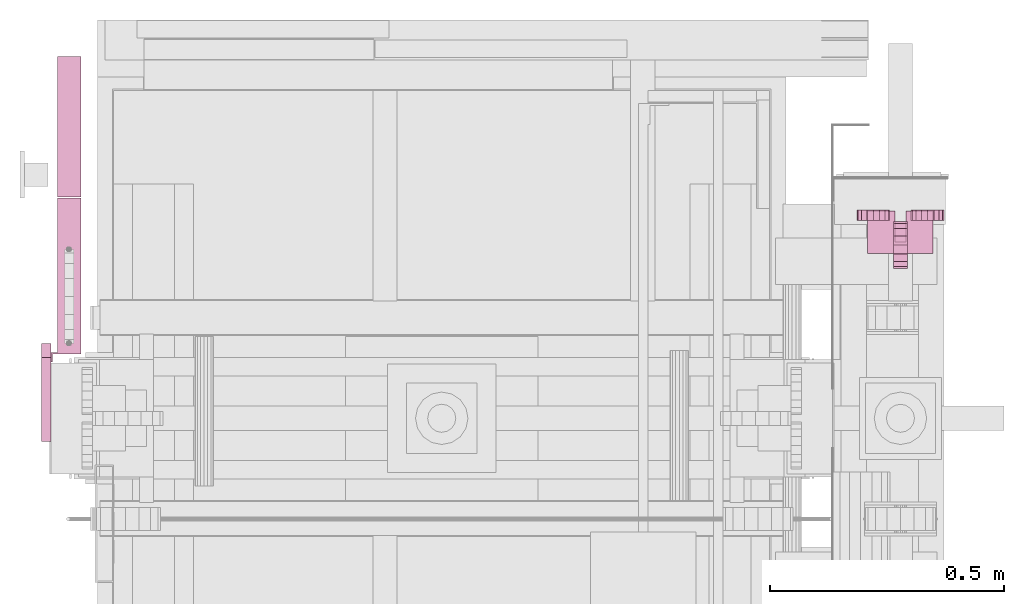
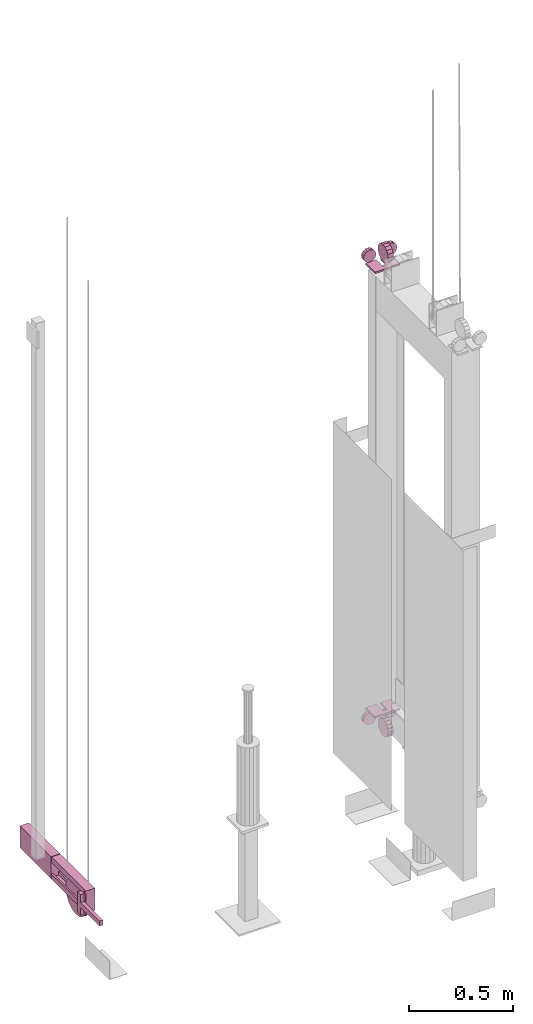
# One storey, part 13 of 13: 3 transport elements.
"""IFC4 building model written with IfcOpenShell, lengths in millimetres."""

from ifc_helpers import new_model, entity, si_unit, converted_unit, frame, origin_with_axes, place, context, subcontext, project, spatial, faceted_brep, element, save


model = new_model("IFC4")

# Units and contexts
context_of_model = context(None, 3, precision=0.01, world=origin_with_axes())
sub_context_1 = subcontext(context_of_model, None, None, "MODEL_VIEW")
sub_context_2 = subcontext(context_of_model, None, None, "MODEL_VIEW")
sub_context_3 = subcontext(context_of_model, None, None, "MODEL_VIEW")
ifc_project = project(units=[converted_unit("PLANEANGLEUNIT", "degree", entity("IfcPlaneAngleMeasure", 0.017453292519943), si_unit("PLANEANGLEUNIT", "RADIAN"), dimensions=[0, 0, 0, 0, 0, 0, 0]), si_unit("LENGTHUNIT", "METRE", prefix="MILLI"), si_unit("MASSUNIT", "GRAM", prefix="KILO"), converted_unit("TIMEUNIT", "year", entity("IfcTimeMeasure", 31557600.0), si_unit("TIMEUNIT", "SECOND"), dimensions=[0, 0, 1, 0, 0, 0, 0]), si_unit("THERMODYNAMICTEMPERATUREUNIT", "DEGREE_CELSIUS"), si_unit("AREAUNIT", "SQUARE_METRE"), si_unit("FORCEUNIT", "NEWTON"), si_unit("VOLUMEUNIT", "CUBIC_METRE"), si_unit("PRESSUREUNIT", "PASCAL"), si_unit("SOLIDANGLEUNIT", "STERADIAN")], contexts=[context_of_model])

# Site, building, storey
site = spatial("IfcSite", under=ifc_project)
building = spatial("IfcBuilding", under=site, Name="Document")
placement = place(None, origin_with_axes())
storey_placement = place(placement, frame((0.0, 0.0, -26400.0), z_axis=(0.0, 0.0, 1.0), x_axis=(1.0, 0.0, 0.0)))
storey = spatial("IfcBuildingStorey", under=building, at=storey_placement, Name="Z -26400", Elevation=-26400.0)

# Transport elements
transport_element_1_placement = place(storey_placement, frame((1879.0, 1447.0, 649.0), z_axis=(0.0, 0.0, -1.0), x_axis=(-1.0, 0.0, 0.0)))
element("IfcTransportElement", 1, at=transport_element_1_placement, inside=storey, ObjectType="R3", PredefinedType="ELEVATOR", context=sub_context_1, shape_type="Brep", body=[
    faceted_brep([(15.0, -52.0, 43.0), (15.0, -32.8658447265625, 46.8060302734375), (15.0, -16.6446533203125, 57.6446533203125), (15.0, -5.8060302734375, 73.8658447265625), (15.0, -2.0, 93.0), (15.0, -5.8060302734375, 112.1341552734375), (15.0, -16.6446533203125, 128.3553466796875), (15.0, -32.8658447265625, 139.1939697265625), (15.0, -52.0, 143.0), (15.0, -71.1341552734375, 139.1939697265625), (15.0, -87.3553466796875, 128.3553466796875), (15.0, -98.1939697265625, 112.1341552734375), (15.0, -102.0, 93.0), (15.0, -98.1939697265625, 73.8658447265625), (15.0, -87.3553466796875, 57.6446533203125), (15.0, -71.1341552734375, 46.8060302734375), (-15.0, -52.0, 43.0), (-15.0, -71.1341552734375, 46.8060302734375), (-15.0, -87.3553466796875, 57.6446533203125), (-15.0, -98.1939697265625, 73.8658447265625), (-15.0, -102.0, 93.0), (-15.0, -98.1939697265625, 112.1341552734375), (-15.0, -87.3553466796875, 128.3553466796875), (-15.0, -71.1341552734375, 139.1939697265625), (-15.0, -52.0, 143.0), (-15.0, -32.8658447265625, 139.1939697265625), (-15.0, -16.6446533203125, 128.3553466796875), (-15.0, -5.8060302734375, 112.1341552734375), (-15.0, -2.0, 93.0), (-15.0, -5.8060302734375, 73.8658447265625), (-15.0, -16.6446533203125, 57.6446533203125), (-15.0, -32.8658447265625, 46.8060302734375)], [[[0, 1, 2, 3, 4, 5, 6, 7, 8, 9, 10, 11, 12, 13, 14, 15]], [[16, 17, 18, 19, 20, 21, 22, 23, 24, 25, 26, 27, 28, 29, 30, 31]], [[0, 15, 17, 16]], [[15, 14, 18, 17]], [[14, 13, 19, 18]], [[13, 12, 20, 19]], [[12, 11, 21, 20]], [[11, 10, 22, 21]], [[10, 9, 23, 22]], [[9, 8, 24, 23]], [[8, 7, 25, 24]], [[7, 6, 26, 25]], [[6, 5, 27, 26]], [[5, 4, 28, 27]], [[4, 3, 29, 28]], [[3, 2, 30, 29]], [[2, 1, 31, 30]], [[1, 0, 16, 31]]]),
    faceted_brep([(70.0, -70.0, 0.0), (70.0, 20.0, 0.0), (70.0, 20.0, 10.0), (70.0, -70.0, 10.0), (12.0, 20.0, 10.0), (12.0, 20.0, 0.0), (12.0, -46.0, 0.0), (12.0, -46.0, 10.0), (-12.0, -46.0, 0.0), (-12.0, 20.0, 0.0), (-12.0, 20.0, 10.0), (-12.0, -46.0, 10.0), (-70.0, 20.0, 10.0), (-70.0, 20.0, 0.0), (-70.0, -70.0, 0.0), (-70.0, -70.0, 10.0)], [[[0, 1, 2, 3]], [[4, 5, 6, 7]], [[8, 9, 10, 11]], [[12, 13, 14, 15]], [[15, 14, 0, 3]], [[1, 5, 4, 2]], [[6, 8, 11, 7]], [[9, 13, 12, 10]], [[3, 2, 4, 7, 11, 10, 12, 15]], [[14, 13, 9, 8, 6, 5, 1, 0]]]),
    faceted_brep([(-92.93994140625, 0.0, 58.0), (-90.2757568359375, 0.0, 44.6060791015625), (-82.688720703125, 0.0, 33.25128173828125), (-71.3338623046875, 0.0, 25.66424560546875), (-57.93994140625, 0.0, 23.0), (-44.5460205078125, 0.0, 25.66424560546875), (-33.1912841796875, 0.0, 33.25128173828125), (-25.604248046875, 0.0, 44.6060791015625), (-22.93994140625, 0.0, 58.0), (-25.604248046875, 0.0, 71.3939208984375), (-33.1912841796875, 0.0, 82.74871826171875), (-44.5460205078125, 0.0, 90.33575439453125), (-57.93994140625, 0.0, 93.0), (-71.3338623046875, 0.0, 90.33575439453125), (-82.688720703125, 0.0, 82.74871826171875), (-90.2757568359375, 0.0, 71.3939208984375), (-92.93994140625, 23.0, 58.0), (-90.2757568359375, 23.0, 71.3939208984375), (-82.688720703125, 23.0, 82.74871826171875), (-71.3338623046875, 23.0, 90.33575439453125), (-57.93994140625, 23.0, 93.0), (-44.5460205078125, 23.0, 90.33575439453125), (-33.1912841796875, 23.0, 82.74871826171875), (-25.604248046875, 23.0, 71.3939208984375), (-22.93994140625, 23.0, 58.0), (-25.604248046875, 23.0, 44.6060791015625), (-33.1912841796875, 23.0, 33.25128173828125), (-44.5460205078125, 23.0, 25.66424560546875), (-57.93994140625, 23.0, 23.0), (-71.3338623046875, 23.0, 25.66424560546875), (-82.688720703125, 23.0, 33.25128173828125), (-90.2757568359375, 23.0, 44.6060791015625)], [[[0, 1, 2, 3, 4, 5, 6, 7, 8, 9, 10, 11, 12, 13, 14, 15]], [[16, 17, 18, 19, 20, 21, 22, 23, 24, 25, 26, 27, 28, 29, 30, 31]], [[0, 15, 17, 16]], [[15, 14, 18, 17]], [[14, 13, 19, 18]], [[13, 12, 20, 19]], [[12, 11, 21, 20]], [[11, 10, 22, 21]], [[10, 9, 23, 22]], [[9, 8, 24, 23]], [[8, 7, 25, 24]], [[7, 6, 26, 25]], [[6, 5, 27, 26]], [[5, 4, 28, 27]], [[4, 3, 29, 28]], [[3, 2, 30, 29]], [[2, 1, 31, 30]], [[1, 0, 16, 31]]]),
    faceted_brep([(22.93994140625, 23.0, 58.0), (25.604248046875, 23.0, 71.3939208984375), (33.1912841796875, 23.0, 82.74871826171875), (44.5460205078125, 23.0, 90.33575439453125), (57.93994140625, 23.0, 93.0), (71.3338623046875, 23.0, 90.33575439453125), (82.688720703125, 23.0, 82.74871826171875), (90.2757568359375, 23.0, 71.3939208984375), (92.93994140625, 23.0, 58.0), (90.2757568359375, 23.0, 44.6060791015625), (82.688720703125, 23.0, 33.25128173828125), (71.3338623046875, 23.0, 25.66424560546875), (57.93994140625, 23.0, 23.0), (44.5460205078125, 23.0, 25.66424560546875), (33.1912841796875, 23.0, 33.25128173828125), (25.604248046875, 23.0, 44.6060791015625), (22.93994140625, 0.0, 58.0), (25.604248046875, 0.0, 44.6060791015625), (33.1912841796875, 0.0, 33.25128173828125), (44.5460205078125, 0.0, 25.66424560546875), (57.93994140625, 0.0, 23.0), (71.3338623046875, 0.0, 25.66424560546875), (82.688720703125, 0.0, 33.25128173828125), (90.2757568359375, 0.0, 44.6060791015625), (92.93994140625, 0.0, 58.0), (90.2757568359375, 0.0, 71.3939208984375), (82.688720703125, 0.0, 82.74871826171875), (71.3338623046875, 0.0, 90.33575439453125), (57.93994140625, 0.0, 93.0), (44.5460205078125, 0.0, 90.33575439453125), (33.1912841796875, 0.0, 82.74871826171875), (25.604248046875, 0.0, 71.3939208984375)], [[[0, 1, 2, 3, 4, 5, 6, 7, 8, 9, 10, 11, 12, 13, 14, 15]], [[16, 17, 18, 19, 20, 21, 22, 23, 24, 25, 26, 27, 28, 29, 30, 31]], [[0, 15, 17, 16]], [[15, 14, 18, 17]], [[14, 13, 19, 18]], [[13, 12, 20, 19]], [[12, 11, 21, 20]], [[11, 10, 22, 21]], [[10, 9, 23, 22]], [[9, 8, 24, 23]], [[8, 7, 25, 24]], [[7, 6, 26, 25]], [[6, 5, 27, 26]], [[5, 4, 28, 27]], [[4, 3, 29, 28]], [[3, 2, 30, 29]], [[2, 1, 31, 30]], [[1, 0, 16, 31]]]),
])
transport_element_2_placement = place(storey_placement, frame((1879.0, 1447.0, 3249.0), z_axis=(0.0, 0.0, 1.0), x_axis=(1.0, 0.0, 0.0)))
element("IfcTransportElement", 2, at=transport_element_2_placement, inside=storey, ObjectType="R3", PredefinedType="ELEVATOR", context=sub_context_2, shape_type="Brep", body=[
    faceted_brep([(-92.93994140625, 0.0, 58.0), (-90.2757568359375, 0.0, 44.606201171875), (-82.688720703125, 0.0, 33.251220703125), (-71.3338623046875, 0.0, 25.664306640625), (-57.93994140625, 0.0, 23.0), (-44.5460205078125, 0.0, 25.664306640625), (-33.1912841796875, 0.0, 33.251220703125), (-25.604248046875, 0.0, 44.606201171875), (-22.93994140625, 0.0, 58.0), (-25.604248046875, 0.0, 71.393798828125), (-33.1912841796875, 0.0, 82.748779296875), (-44.5460205078125, 0.0, 90.335693359375), (-57.93994140625, 0.0, 93.0), (-71.3338623046875, 0.0, 90.335693359375), (-82.688720703125, 0.0, 82.748779296875), (-90.2757568359375, 0.0, 71.393798828125), (-92.93994140625, 23.0, 58.0), (-90.2757568359375, 23.0, 71.393798828125), (-82.688720703125, 23.0, 82.748779296875), (-71.3338623046875, 23.0, 90.335693359375), (-57.93994140625, 23.0, 93.0), (-44.5460205078125, 23.0, 90.335693359375), (-33.1912841796875, 23.0, 82.748779296875), (-25.604248046875, 23.0, 71.393798828125), (-22.93994140625, 23.0, 58.0), (-25.604248046875, 23.0, 44.606201171875), (-33.1912841796875, 23.0, 33.251220703125), (-44.5460205078125, 23.0, 25.664306640625), (-57.93994140625, 23.0, 23.0), (-71.3338623046875, 23.0, 25.664306640625), (-82.688720703125, 23.0, 33.251220703125), (-90.2757568359375, 23.0, 44.606201171875)], [[[0, 1, 2, 3, 4, 5, 6, 7, 8, 9, 10, 11, 12, 13, 14, 15]], [[16, 17, 18, 19, 20, 21, 22, 23, 24, 25, 26, 27, 28, 29, 30, 31]], [[0, 15, 17, 16]], [[15, 14, 18, 17]], [[14, 13, 19, 18]], [[13, 12, 20, 19]], [[12, 11, 21, 20]], [[11, 10, 22, 21]], [[10, 9, 23, 22]], [[9, 8, 24, 23]], [[8, 7, 25, 24]], [[7, 6, 26, 25]], [[6, 5, 27, 26]], [[5, 4, 28, 27]], [[4, 3, 29, 28]], [[3, 2, 30, 29]], [[2, 1, 31, 30]], [[1, 0, 16, 31]]]),
    faceted_brep([(15.0, -52.0, 43.0), (15.0, -32.8658447265625, 46.805908203125), (15.0, -16.6446533203125, 57.644775390625), (15.0, -5.8060302734375, 73.86572265625), (15.0, -2.0, 93.0), (15.0, -5.8060302734375, 112.13427734375), (15.0, -16.6446533203125, 128.355224609375), (15.0, -32.8658447265625, 139.194091796875), (15.0, -52.0, 143.0), (15.0, -71.1341552734375, 139.194091796875), (15.0, -87.3553466796875, 128.355224609375), (15.0, -98.1939697265625, 112.13427734375), (15.0, -102.0, 93.0), (15.0, -98.1939697265625, 73.86572265625), (15.0, -87.3553466796875, 57.644775390625), (15.0, -71.1341552734375, 46.805908203125), (-15.0, -52.0, 43.0), (-15.0, -71.1341552734375, 46.805908203125), (-15.0, -87.3553466796875, 57.644775390625), (-15.0, -98.1939697265625, 73.86572265625), (-15.0, -102.0, 93.0), (-15.0, -98.1939697265625, 112.13427734375), (-15.0, -87.3553466796875, 128.355224609375), (-15.0, -71.1341552734375, 139.194091796875), (-15.0, -52.0, 143.0), (-15.0, -32.8658447265625, 139.194091796875), (-15.0, -16.6446533203125, 128.355224609375), (-15.0, -5.8060302734375, 112.13427734375), (-15.0, -2.0, 93.0), (-15.0, -5.8060302734375, 73.86572265625), (-15.0, -16.6446533203125, 57.644775390625), (-15.0, -32.8658447265625, 46.805908203125)], [[[0, 1, 2, 3, 4, 5, 6, 7, 8, 9, 10, 11, 12, 13, 14, 15]], [[16, 17, 18, 19, 20, 21, 22, 23, 24, 25, 26, 27, 28, 29, 30, 31]], [[0, 15, 17, 16]], [[15, 14, 18, 17]], [[14, 13, 19, 18]], [[13, 12, 20, 19]], [[12, 11, 21, 20]], [[11, 10, 22, 21]], [[10, 9, 23, 22]], [[9, 8, 24, 23]], [[8, 7, 25, 24]], [[7, 6, 26, 25]], [[6, 5, 27, 26]], [[5, 4, 28, 27]], [[4, 3, 29, 28]], [[3, 2, 30, 29]], [[2, 1, 31, 30]], [[1, 0, 16, 31]]]),
    faceted_brep([(22.93994140625, 23.0, 58.0), (25.604248046875, 23.0, 71.393798828125), (33.1912841796875, 23.0, 82.748779296875), (44.5460205078125, 23.0, 90.335693359375), (57.93994140625, 23.0, 93.0), (71.3338623046875, 23.0, 90.335693359375), (82.688720703125, 23.0, 82.748779296875), (90.2757568359375, 23.0, 71.393798828125), (92.93994140625, 23.0, 58.0), (90.2757568359375, 23.0, 44.606201171875), (82.688720703125, 23.0, 33.251220703125), (71.3338623046875, 23.0, 25.664306640625), (57.93994140625, 23.0, 23.0), (44.5460205078125, 23.0, 25.664306640625), (33.1912841796875, 23.0, 33.251220703125), (25.604248046875, 23.0, 44.606201171875), (22.93994140625, 0.0, 58.0), (25.604248046875, 0.0, 44.606201171875), (33.1912841796875, 0.0, 33.251220703125), (44.5460205078125, 0.0, 25.664306640625), (57.93994140625, 0.0, 23.0), (71.3338623046875, 0.0, 25.664306640625), (82.688720703125, 0.0, 33.251220703125), (90.2757568359375, 0.0, 44.606201171875), (92.93994140625, 0.0, 58.0), (90.2757568359375, 0.0, 71.393798828125), (82.688720703125, 0.0, 82.748779296875), (71.3338623046875, 0.0, 90.335693359375), (57.93994140625, 0.0, 93.0), (44.5460205078125, 0.0, 90.335693359375), (33.1912841796875, 0.0, 82.748779296875), (25.604248046875, 0.0, 71.393798828125)], [[[0, 1, 2, 3, 4, 5, 6, 7, 8, 9, 10, 11, 12, 13, 14, 15]], [[16, 17, 18, 19, 20, 21, 22, 23, 24, 25, 26, 27, 28, 29, 30, 31]], [[0, 15, 17, 16]], [[15, 14, 18, 17]], [[14, 13, 19, 18]], [[13, 12, 20, 19]], [[12, 11, 21, 20]], [[11, 10, 22, 21]], [[10, 9, 23, 22]], [[9, 8, 24, 23]], [[8, 7, 25, 24]], [[7, 6, 26, 25]], [[6, 5, 27, 26]], [[5, 4, 28, 27]], [[4, 3, 29, 28]], [[3, 2, 30, 29]], [[2, 1, 31, 30]], [[1, 0, 16, 31]]]),
    faceted_brep([(-70.0, -70.0, 10.0), (-70.0, 20.0, 10.0), (-70.0, 20.0, 0.0), (-70.0, -70.0, 0.0), (-12.0, 20.0, 0.0), (-12.0, 20.0, 10.0), (-12.0, -46.0, 10.0), (-12.0, -46.0, 0.0), (12.0, -46.0, 10.0), (12.0, 20.0, 10.0), (12.0, 20.0, 0.0), (12.0, -46.0, 0.0), (70.0, 20.0, 0.0), (70.0, 20.0, 10.0), (70.0, -70.0, 10.0), (70.0, -70.0, 0.0)], [[[0, 1, 2, 3]], [[4, 5, 6, 7]], [[8, 9, 10, 11]], [[12, 13, 14, 15]], [[15, 14, 0, 3]], [[1, 5, 4, 2]], [[6, 8, 11, 7]], [[9, 13, 12, 10]], [[2, 4, 7, 11, 10, 12, 15, 3]], [[0, 14, 13, 9, 8, 6, 5, 1]]]),
])
transport_element_3_placement = place(storey_placement, frame((105.0, 1285.0, 245.0), z_axis=(0.0, 0.0, 1.0), x_axis=(0.0, 1.0, 0.0)))
element("IfcTransportElement", 3, at=transport_element_3_placement, inside=storey, Name="TW0", ObjectType="-GBP Tension Weight", PredefinedType="ELEVATOR", context=sub_context_3, shape_type="Brep", body=[
    faceted_brep([(0.0, -10.0, -100.0), (38.268310546875, -10.0, -92.38795471191406), (70.710693359375, -10.0, -70.71067810058594), (92.387939453125, -10.0, -38.268341064453125), (100.0, -10.0, 0.0), (92.387939453125, -10.0, 38.268341064453125), (70.710693359375, -10.0, 70.710693359375), (38.268310546875, -10.0, 92.387939453125), (0.0, -10.0, 100.0), (-38.268310546875, -10.000000000000014, 92.387939453125), (-70.710693359375, -10.000000000000014, 70.710693359375), (-92.387939453125, -10.000000000000014, 38.268341064453125), (-100.0, -10.000000000000014, 0.0), (-92.387939453125, -10.000000000000014, -38.268341064453125), (-70.710693359375, -10.000000000000014, -70.71067810058594), (-38.268310546875, -10.000000000000014, -92.38795471191406), (0.0, 10.0, -100.0), (-38.268310546875, 9.999999999999986, -92.38795471191406), (-70.710693359375, 9.999999999999986, -70.71067810058594), (-92.387939453125, 9.999999999999986, -38.268341064453125), (-100.0, 9.999999999999986, 0.0), (-92.387939453125, 9.999999999999986, 38.268341064453125), (-70.710693359375, 9.999999999999986, 70.710693359375), (-38.268310546875, 9.999999999999986, 92.387939453125), (0.0, 10.0, 100.0), (38.268310546875, 10.0, 92.387939453125), (70.710693359375, 10.0, 70.710693359375), (92.387939453125, 10.0, 38.268341064453125), (100.0, 10.0, 0.0), (92.387939453125, 10.0, -38.268341064453125), (70.710693359375, 10.0, -70.71067810058594), (38.268310546875, 10.0, -92.38795471191406)], [[[0, 1, 2, 3, 4, 5, 6, 7, 8, 9, 10, 11, 12, 13, 14, 15]], [[16, 17, 18, 19, 20, 21, 22, 23, 24, 25, 26, 27, 28, 29, 30, 31]], [[0, 15, 17, 16]], [[15, 14, 18, 17]], [[14, 13, 19, 18]], [[13, 12, 20, 19]], [[12, 11, 21, 20]], [[11, 10, 22, 21]], [[10, 9, 23, 22]], [[9, 8, 24, 23]], [[8, 7, 25, 24]], [[7, 6, 26, 25]], [[6, 5, 27, 26]], [[5, 4, 28, 27]], [[4, 3, 29, 28]], [[3, 2, 30, 29]], [[2, 1, 31, 30]], [[1, 0, 16, 31]]]),
    faceted_brep([(-120.0, 24.999999999999986, 115.0), (210.0, 25.0, 115.0), (210.0, 25.0, 85.0), (-120.0, 24.999999999999986, 85.0), (210.0, 15.0, 85.0), (210.0, 15.0, 105.0), (-120.0, 14.999999999999986, 105.0), (-120.0, 14.999999999999986, 85.0), (-120.0, -15.000000000000014, 105.0), (210.0, -15.0, 105.0), (210.0, -15.0, 85.0), (-120.0, -15.000000000000014, 85.0), (210.0, -25.0, 85.0), (210.0, -25.0, 115.0), (-120.0, -25.0, 115.0), (-120.0, -25.0, 85.0)], [[[0, 1, 2, 3]], [[4, 5, 6, 7]], [[8, 9, 10, 11]], [[12, 13, 14, 15]], [[7, 6, 8, 11, 15, 14, 0, 3]], [[1, 13, 12, 10, 9, 5, 4, 2]], [[2, 4, 7, 3]], [[14, 13, 1, 0]], [[5, 9, 8, 6]], [[10, 12, 15, 11]]]),
    faceted_brep([(-310.0, 58.99999999999997, 65.0), (-130.0, 58.999999999999986, 65.0), (-130.0, 58.999999999999986, 110.0), (-100.0, 58.999999999999986, 110.0), (-100.0, 58.999999999999986, -10.0), (-130.0, 58.999999999999986, -10.0), (-130.0, 58.999999999999986, 35.0), (-310.0, 58.99999999999997, 35.0), (-130.0, 38.999999999999986, 35.0), (-130.0, 38.999999999999986, -10.0), (-100.0, 38.999999999999986, -10.0), (-100.0, 38.999999999999986, 110.0), (-130.0, 38.999999999999986, 110.0), (-130.0, 38.999999999999986, 65.0), (-310.0, 38.99999999999997, 65.0), (-310.0, 38.99999999999997, 35.0)], [[[0, 1, 2, 3, 4, 5, 6, 7]], [[8, 9, 10, 11, 12, 13, 14, 15]], [[15, 14, 0, 7]], [[9, 8, 6, 5]], [[3, 11, 10, 4]], [[13, 12, 2, 1]], [[6, 8, 15, 7]], [[14, 13, 1, 0]], [[4, 10, 9, 5]], [[12, 11, 3, 2]]]),
    faceted_brep([(212.0, 25.0, -15.0), (212.0, 25.0, 115.0), (512.0, 25.00000000000003, 115.0), (512.0, 25.00000000000003, -15.0), (212.0, -25.0, -15.0), (512.0, -24.99999999999997, -15.0), (512.0, -24.99999999999997, 115.0), (212.0, -25.0, 115.0)], [[[0, 1, 2, 3]], [[4, 5, 6, 7]], [[0, 3, 5, 4]], [[3, 2, 6, 5]], [[2, 1, 7, 6]], [[1, 0, 4, 7]]]),
    faceted_brep([(-120.0, 24.999999999999986, 15.0), (210.0, 25.0, 15.0), (210.0, 25.0, -15.0), (-120.0, 24.999999999999986, -15.0), (210.0, 15.0, -5.0), (210.0, 15.0, 15.0), (-120.0, 14.999999999999986, 15.0), (-120.0, 14.999999999999986, -5.0), (-120.0, -15.000000000000014, 15.0), (210.0, -15.0, 15.0), (210.0, -15.0, -5.0), (-120.0, -15.000000000000014, -5.0), (210.0, -25.0, -15.0), (210.0, -25.0, 15.0), (-120.0, -25.0, 15.0), (-120.0, -25.0, -15.0)], [[[0, 1, 2, 3]], [[4, 5, 6, 7]], [[8, 9, 10, 11]], [[12, 13, 14, 15]], [[15, 14, 8, 11, 7, 6, 0, 3]], [[2, 1, 5, 4, 10, 9, 13, 12]], [[2, 12, 15, 3]], [[11, 10, 4, 7]], [[6, 5, 1, 0]], [[14, 13, 9, 8]]]),
    faceted_brep([(-140.0, 38.999999999999986, 115.0), (-120.0, 38.999999999999986, 115.0), (-120.0, 38.999999999999986, -15.0), (-140.0, 38.999999999999986, -15.0), (-123.0, 35.999999999999986, -15.0), (-123.0, 35.999999999999986, 115.0), (-140.0, 35.999999999999986, 115.0), (-140.0, 35.999999999999986, -15.0), (-120.0, -25.0, -15.0), (-120.0, -25.0, 115.0), (-123.0, -25.0, 115.0), (-123.0, -25.0, -15.0)], [[[0, 1, 2, 3]], [[4, 5, 6, 7]], [[8, 9, 10, 11]], [[7, 6, 0, 3]], [[1, 9, 8, 2]], [[11, 10, 5, 4]], [[2, 8, 11, 4, 7, 3]], [[6, 5, 10, 9, 1, 0]]]),
])

save(model, "model.ifc")
